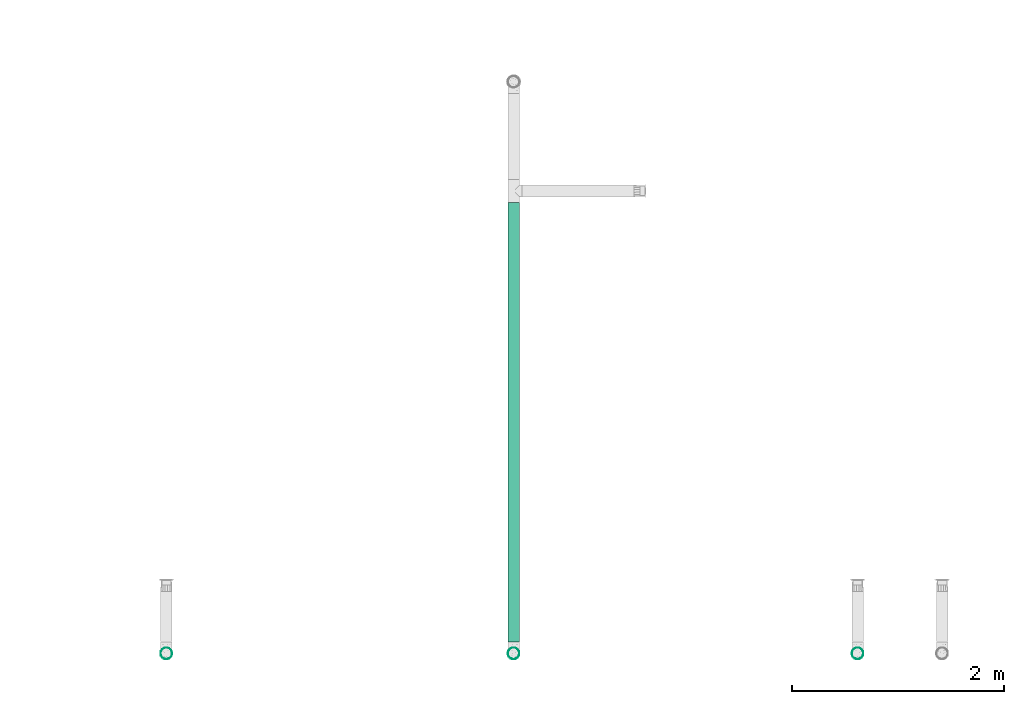
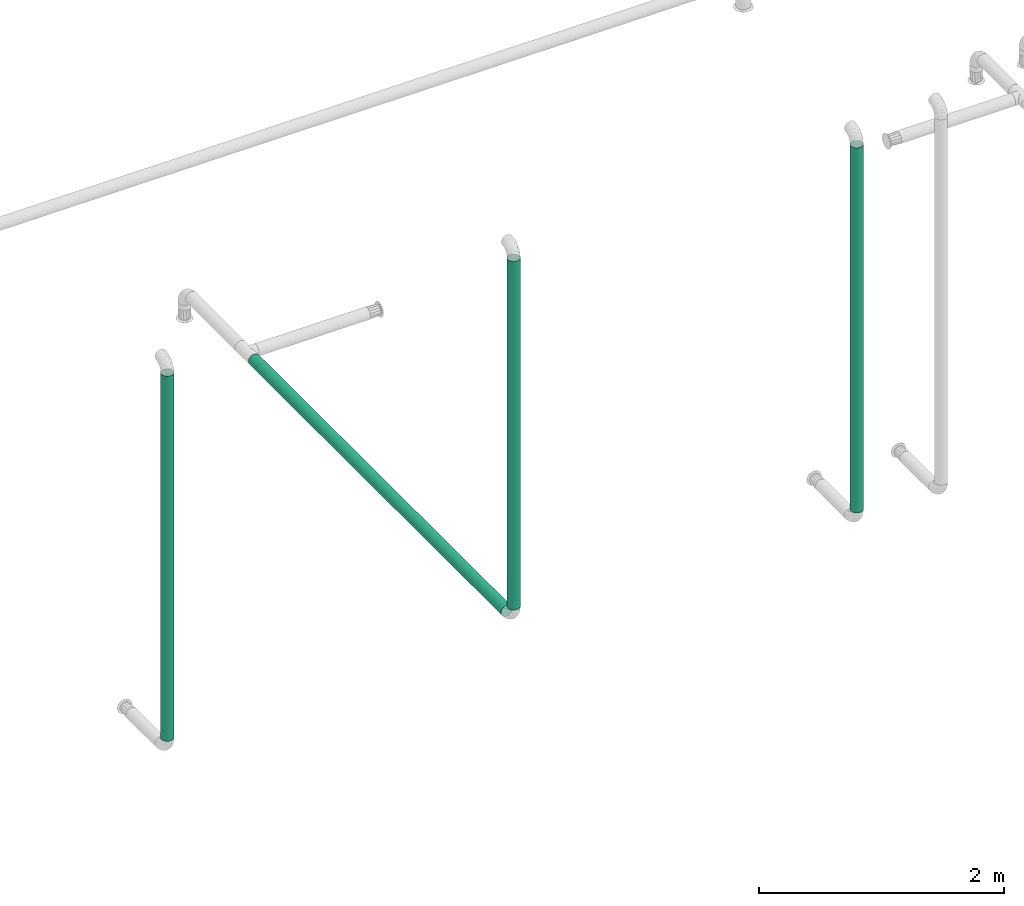
# One storey, part 5 of 115: 4 flow segments.
"""IFC2X3 building model written with IfcOpenShell, lengths in millimetres."""

from ifc_helpers import new_model, entity, si_unit, converted_unit, derived_unit, direction, frame, origin_with_axes, origin_2d_with_axis, place, context, subcontext, project, spatial, hollow_circle, extrude, source, transform, mapped, material, layer, layer_set, layer_usage, type_object, element, save


model = new_model("IFC2X3")

# Units and contexts
model_context = context("Model", 3, precision=1e-05, world=origin_with_axes(), true_north=direction((0.0, 1.0)))
body_context = subcontext(model_context, "Body", "Model", "MODEL_VIEW")
ifc_project = project(units=[si_unit("AREAUNIT", "SQUARE_METRE"), si_unit("VOLUMEUNIT", "CUBIC_METRE", prefix="DECI"), si_unit("TIMEUNIT", "SECOND"), si_unit("THERMODYNAMICTEMPERATUREUNIT", "DEGREE_CELSIUS"), si_unit("PRESSUREUNIT", "PASCAL"), si_unit("MASSUNIT", "GRAM", prefix="KILO"), si_unit("LENGTHUNIT", "METRE", prefix="MILLI"), si_unit("POWERUNIT", "WATT"), si_unit("ELECTRICCURRENTUNIT", "AMPERE"), si_unit("ELECTRICVOLTAGEUNIT", "VOLT"), derived_unit("VOLUMETRICFLOWRATEUNIT", [(si_unit("VOLUMEUNIT", "CUBIC_METRE", prefix="DECI"), 1), (si_unit("TIMEUNIT", "SECOND"), -1)]), derived_unit("LINEARVELOCITYUNIT", [(si_unit("LENGTHUNIT", "METRE"), 1), (si_unit("TIMEUNIT", "SECOND"), -1)]), derived_unit("MASSDENSITYUNIT", [(si_unit("MASSUNIT", "GRAM", prefix="KILO"), 1), (si_unit("VOLUMEUNIT", "CUBIC_METRE"), -1)]), converted_unit("PLANEANGLEUNIT", "DEGREE", entity("IfcRatioMeasure", 0.01745), si_unit("PLANEANGLEUNIT", "RADIAN"), dimensions=[0, 0, 0, 0, 0, 0, 0])], contexts=[model_context])

# Site, building, storey
site_placement = place(None, origin_with_axes())
site = spatial("IfcSite", under=ifc_project, at=site_placement, CompositionType="ELEMENT")
building_placement = place(site_placement, origin_with_axes())
building = spatial("IfcBuilding", under=site, at=building_placement, Name="mc-building", CompositionType="ELEMENT")
storey_placement = place(building_placement, frame((0.0, 0.0, 2950.0), z_axis=(0.0, 0.0, 1.0), x_axis=(1.0, 0.0, 0.0)))
storey = spatial("IfcBuildingStorey", under=building, at=storey_placement, Name="2. Korrus", CompositionType="ELEMENT", Elevation=2950.0)

# Flow segments
ifc_material = material(Name="FZ1")
ifc_layer = layer(ifc_material, 0.0)
ifc_layer_set = layer_set([ifc_layer], Name="FZ1")
ifc_layer_usage = layer_usage(ifc_layer_set, "AXIS1", "POSITIVE", 0.0)
duct_segment_type_1 = type_object("IfcDuctSegmentType", PredefinedType="RIGIDSEGMENT")
shared_shape_1 = source(origin_with_axes(), body_context, "Body", "SweptSolid", [
    extrude(hollow_circle(Radius=55.0, WallThickness=2.0, at=origin_2d_with_axis()), frame((0.0, 0.0, 0.0), z_axis=(1.0, 0.0, 0.0), x_axis=(0.0, 1.0, 0.0)), (0.0, 0.0, 1.0), 3480.0),
])
flow_segment_1_placement = place(storey_placement, frame((22753.47863, -687.64676, 2575.0), z_axis=(1.0, 0.0, 0.0), x_axis=(0.0, 0.0, 1.0)))
element("IfcFlowSegment", 1, at=flow_segment_1_placement, inside=storey, type_object=duct_segment_type_1, material=ifc_layer_usage, context=body_context, shape_type="MappedRepresentation", body=[
    mapped(shared_shape_1, transform((0.0, 0.0, 0.0), scale=1.0)),
])
duct_segment_type_2 = type_object("IfcDuctSegmentType", Name="Safe", PredefinedType="RIGIDSEGMENT")
shared_shape_2 = source(origin_with_axes(), body_context, "Body", "SweptSolid", [
    extrude(hollow_circle(Radius=55.0, WallThickness=2.0, at=origin_2d_with_axis()), frame((0.0, 0.0, 0.0), z_axis=(1.0, 0.0, 0.0), x_axis=(0.0, 1.0, 0.0)), (0.0, 0.0, 1.0), 3645.0),
])
for number, where, z_axis, x_axis, name in (
    (2, (25991.68775, -687.64676, 2410.0), (1.0, 0.0, 0.0), (0.0, 0.0, 1.0), "Safe"),
    (3, (19483.88525, -687.64676, 2410.0), (1.0, 0.0, 0.0), (0.0, 0.0, 1.0), "Safe"),
):
    element("IfcFlowSegment", number, at=place(storey_placement, frame(where, z_axis=z_axis, x_axis=x_axis)), inside=storey, type_object=duct_segment_type_2, material=ifc_layer_usage, Name=name, context=body_context, shape_type="MappedRepresentation", body=[
        mapped(shared_shape_2, transform((0.0, 0.0, 0.0), scale=1.0)),
    ])
shared_shape_3 = source(origin_with_axes(), body_context, "Body", "SweptSolid", [
    extrude(hollow_circle(Radius=55.0, WallThickness=2.0, at=origin_2d_with_axis()), frame((0.0, 0.0, 0.0), z_axis=(1.0, 0.0, 0.0), x_axis=(0.0, 1.0, 0.0)), (0.0, 0.0, 1.0), 4133.9),
])
flow_segment_2_placement = place(storey_placement, frame((22753.47863, -577.64676, 2465.0), z_axis=(0.0, 0.0, 1.0), x_axis=(0.0, 1.0, 0.0)))
element("IfcFlowSegment", 4, at=flow_segment_2_placement, inside=storey, type_object=duct_segment_type_1, material=ifc_layer_usage, context=body_context, shape_type="MappedRepresentation", body=[
    mapped(shared_shape_3, transform((0.0, 0.0, 0.0), scale=1.0)),
])

save(model, "model.ifc")
